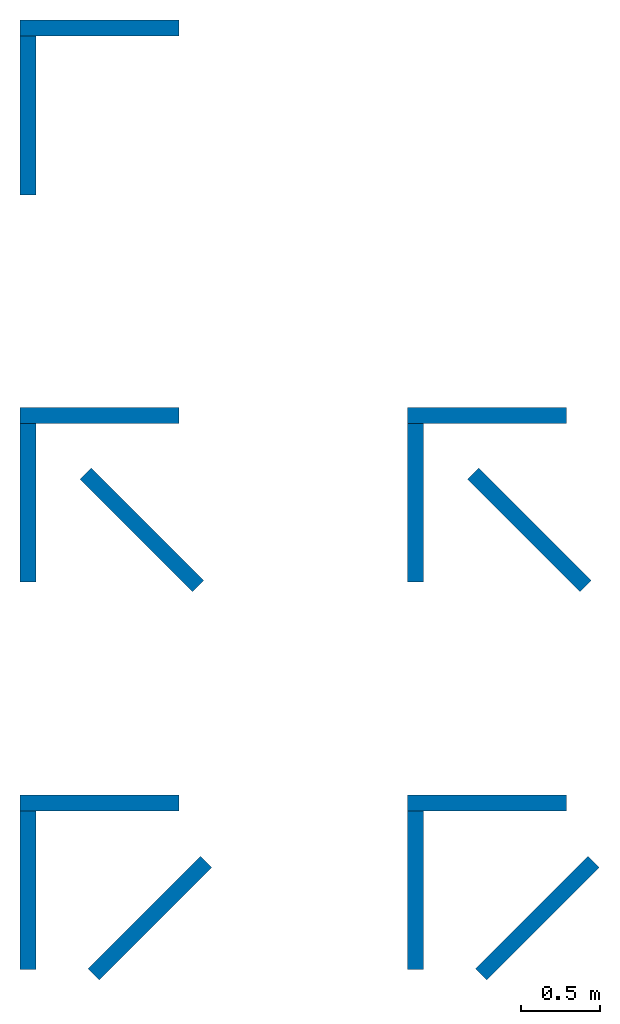
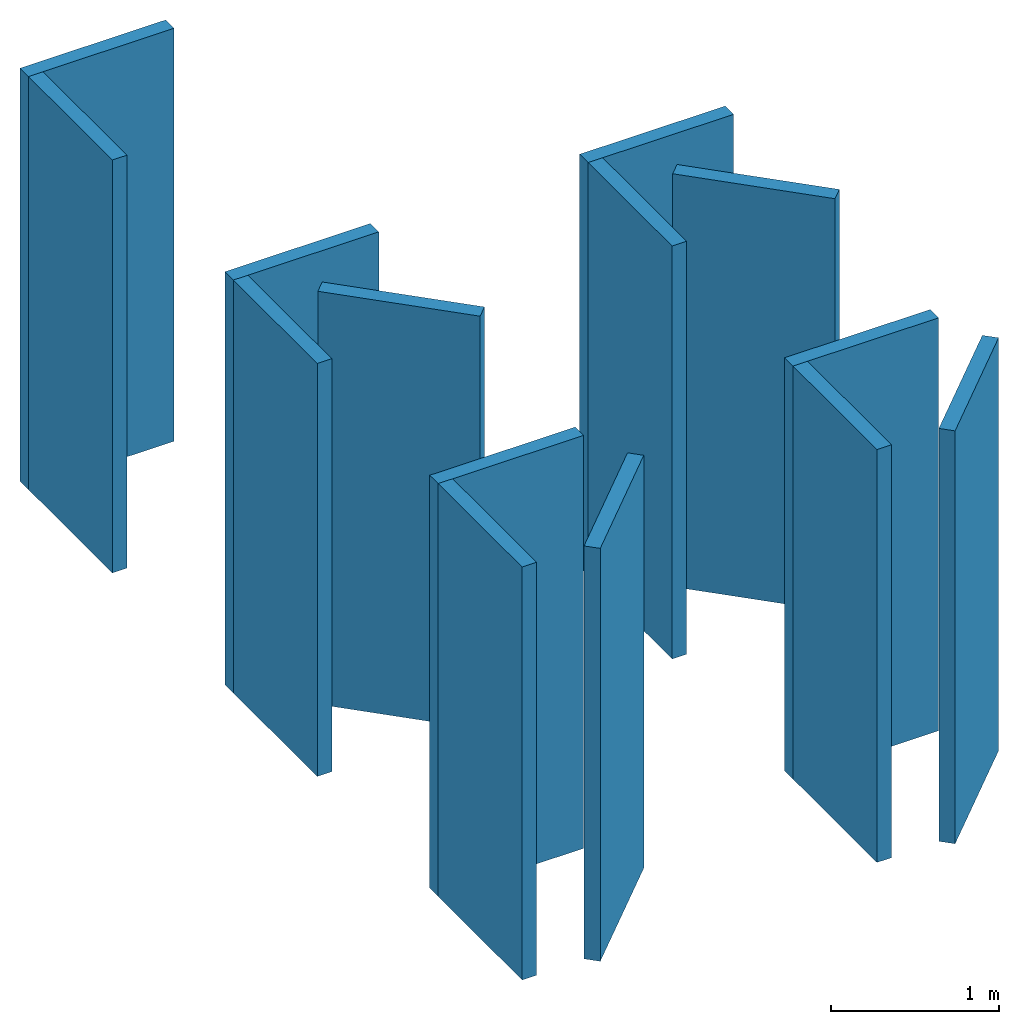
# One storey: 14 walls, 9 elements without a shape of their own.
"""IFC4 building model written with IfcOpenShell, lengths in feet."""

from ifc_helpers import new_model, entity, si_unit, converted_unit, frame, origin_with_axes, origin_2d_with_axis, place, context, subcontext, project, spatial, indexed_curve, outline, extrude, material, layer, layer_set, layer_usage, type_object, element, aggregate, save


model = new_model("IFC4")

# Units and contexts
model_context = context("Model", 3, precision=1e-05, world=origin_with_axes())
plan_context = context("Plan", 2, precision=1e-05, world=origin_2d_with_axis())
body_context = subcontext(model_context, "Body", "Model", "MODEL_VIEW")
ifc_project = project(units=[converted_unit("PLANEANGLEUNIT", "degree", entity("IfcReal", 0.0174532925199433), si_unit("PLANEANGLEUNIT", "RADIAN"), dimensions=[0, 0, 0, 0, 0, 0, 0]), converted_unit("AREAUNIT", "square foot", entity("IfcReal", 0.09290304), si_unit("AREAUNIT", "SQUARE_METRE"), dimensions=[2, 0, 0, 0, 0, 0, 0]), converted_unit("LENGTHUNIT", "foot", entity("IfcReal", 0.3048), si_unit("LENGTHUNIT", "METRE"), dimensions=[1, 0, 0, 0, 0, 0, 0]), converted_unit("VOLUMEUNIT", "cubic foot", entity("IfcReal", 0.0283168467116885), si_unit("VOLUMEUNIT", "CUBIC_METRE"), dimensions=[3, 0, 0, 0, 0, 0, 0])], contexts=[model_context, plan_context])

# Site, building, storey
site_placement = place(None, origin_with_axes())
site = spatial("IfcSite", under=ifc_project, at=site_placement)
building_placement = place(site_placement, origin_with_axes())
building = spatial("IfcBuilding", under=site, at=building_placement, Name="Building")
storey_placement = place(building_placement, origin_with_axes())
storey = spatial("IfcBuildingStorey", under=building, at=storey_placement, Name="Storey")

# Assembly, walls
assembly_1_placement = place(storey_placement, origin_with_axes())
assembly_1 = element("IfcElementAssembly", 1, at=assembly_1_placement, inside=storey, Name="A")
ifc_material = material()
ifc_layer = layer(ifc_material, 0.328083989501312)
ifc_layer_set = layer_set([ifc_layer])
ifc_layer_usage_1 = layer_usage(ifc_layer_set, "AXIS2", "POSITIVE", 0.0)
wall_type = type_object("IfcWallType", Name="WAL100", PredefinedType="NOTDEFINED", material=ifc_layer_set)
wall_1_placement = place(assembly_1_placement, origin_with_axes())
wall_1 = element("IfcWall", 2, at=wall_1_placement, type_object=wall_type, material=ifc_layer_usage_1, Name="Wall", context=body_context, shape_type="SweptSolid", body=[
    extrude(outline(indexed_curve([(0.0, 0.0), (0.0, 0.328083989501312), (3.28083989501312, 0.328083989501312), (3.28083989501312, 0.0), (0.0, 0.0)], self_intersect=False)), origin_with_axes(), (0.0, 0.0, 1.0), 9.84251968503937),
])
ifc_layer_usage_2 = layer_usage(ifc_layer_set, "AXIS2", "POSITIVE", 0.0)
wall_2_placement = place(assembly_1_placement, frame((0.0, 0.0, 0.0), z_axis=(0.0, 0.0, 1.0), x_axis=(-4.37113882867379e-08, -0.999999999999999, 0.0)))
wall_2 = element("IfcWall", 3, at=wall_2_placement, type_object=wall_type, material=ifc_layer_usage_2, Name="Wall", context=body_context, shape_type="SweptSolid", body=[
    extrude(outline(indexed_curve([(0.0, 0.0), (0.0, 0.328083989501312), (3.28083989501312, 0.328083989501312), (3.28083989501312, 0.0), (0.0, 0.0)], self_intersect=False)), origin_with_axes(), (0.0, 0.0, 1.0), 9.84251968503937),
])
aggregate(assembly_1, [wall_1, wall_2])

# Assemblies, walls
assembly_2_placement = place(storey_placement, origin_with_axes())
assembly_2 = element("IfcElementAssembly", 4, at=assembly_2_placement, inside=storey, Name="B")
assembly_3_placement = place(assembly_2_placement, frame((0.0, -8.00000009887175, 0.0), z_axis=(0.0, 0.0, 1.0), x_axis=(1.0, 0.0, 0.0)))
assembly_3 = element("IfcElementAssembly", 5, at=assembly_3_placement, Name="A_Child")
ifc_layer_usage_3 = layer_usage(ifc_layer_set, "AXIS2", "POSITIVE", 0.0)
wall_3_placement = place(assembly_3_placement, origin_with_axes())
wall_3 = element("IfcWall", 6, at=wall_3_placement, type_object=wall_type, material=ifc_layer_usage_3, Name="Wall", context=body_context, shape_type="SweptSolid", body=[
    extrude(outline(indexed_curve([(0.0, 0.0), (0.0, 0.328083989501312), (3.28083989501312, 0.328083989501312), (3.28083989501312, 0.0), (0.0, 0.0)], self_intersect=False)), origin_with_axes(), (0.0, 0.0, 1.0), 9.84251968503937),
])
ifc_layer_usage_4 = layer_usage(ifc_layer_set, "AXIS2", "POSITIVE", 0.0)
wall_4_placement = place(assembly_3_placement, frame((0.0, 0.0, 0.0), z_axis=(0.0, 0.0, 1.0), x_axis=(7.54979012640431e-08, -0.999999999999997, 0.0)))
wall_4 = element("IfcWall", 7, at=wall_4_placement, type_object=wall_type, material=ifc_layer_usage_4, Name="Wall", context=body_context, shape_type="SweptSolid", body=[
    extrude(outline(indexed_curve([(0.0, 0.0), (0.0, 0.328083989501312), (3.28083989501312, 0.328083989501312), (3.28083989501312, 0.0), (0.0, 0.0)], self_intersect=False)), origin_with_axes(), (0.0, 0.0, 1.0), 9.84251968503937),
])
aggregate(assembly_3, [wall_3, wall_4])

assembly_4_placement = place(storey_placement, origin_with_axes())
assembly_4 = element("IfcElementAssembly", 8, at=assembly_4_placement, inside=storey, Name="C")
assembly_5_placement = place(assembly_4_placement, frame((0.0, -16.0000001977435, 0.0), z_axis=(0.0, 0.0, 1.0), x_axis=(1.0, 0.0, 0.0)))
assembly_5 = element("IfcElementAssembly", 9, at=assembly_5_placement, Name="A_Child")
ifc_layer_usage_5 = layer_usage(ifc_layer_set, "AXIS2", "POSITIVE", 0.0)
wall_5_placement = place(assembly_5_placement, origin_with_axes())
wall_5 = element("IfcWall", 10, at=wall_5_placement, type_object=wall_type, material=ifc_layer_usage_5, Name="Wall", context=body_context, shape_type="SweptSolid", body=[
    extrude(outline(indexed_curve([(0.0, 0.0), (0.0, 0.328083989501312), (3.28083989501312, 0.328083989501312), (3.28083989501312, 0.0), (0.0, 0.0)], self_intersect=False)), origin_with_axes(), (0.0, 0.0, 1.0), 9.84251968503937),
])
ifc_layer_usage_6 = layer_usage(ifc_layer_set, "AXIS2", "POSITIVE", 0.0)
wall_6_placement = place(assembly_5_placement, frame((0.0, 0.0, 0.0), z_axis=(0.0, 0.0, 1.0), x_axis=(7.54979012640431e-08, -0.999999999999997, 0.0)))
wall_6 = element("IfcWall", 11, at=wall_6_placement, type_object=wall_type, material=ifc_layer_usage_6, Name="Wall", context=body_context, shape_type="SweptSolid", body=[
    extrude(outline(indexed_curve([(0.0, 0.0), (0.0, 0.328083989501312), (3.28083989501312, 0.328083989501312), (3.28083989501312, 0.0), (0.0, 0.0)], self_intersect=False)), origin_with_axes(), (0.0, 0.0, 1.0), 9.84251968503937),
])
aggregate(assembly_5, [wall_5, wall_6])

# Wall
ifc_layer_usage_7 = layer_usage(ifc_layer_set, "AXIS2", "POSITIVE", 0.0)
wall_7_placement = place(assembly_2_placement, frame((1.23934209190329, -9.15625433283528, 0.0), z_axis=(0.0, 0.0, 1.0), x_axis=(0.707106781186547, -0.707106781186547, 0.0)))
wall_7 = element("IfcWall", 12, at=wall_7_placement, type_object=wall_type, material=ifc_layer_usage_7, Name="Wall", context=body_context, shape_type="SweptSolid", body=[
    extrude(outline(indexed_curve([(0.0, 0.0), (0.0, 0.328083989501312), (3.28083989501312, 0.328083989501312), (3.28083989501312, 0.0), (0.0, 0.0)], self_intersect=False)), origin_with_axes(), (0.0, 0.0, 1.0), 9.84251968503937),
])

aggregate(assembly_2, [assembly_3, wall_7])

ifc_layer_usage_8 = layer_usage(ifc_layer_set, "AXIS2", "POSITIVE", 0.0)
wall_8_placement = place(assembly_4_placement, frame((1.63824568817935, -19.4932985806403, 0.0), z_axis=(0.0, 0.0, 1.0), x_axis=(0.707106781186547, 0.707106781186547, 0.0)))
wall_8 = element("IfcWall", 13, at=wall_8_placement, type_object=wall_type, material=ifc_layer_usage_8, Name="Wall", context=body_context, shape_type="SweptSolid", body=[
    extrude(outline(indexed_curve([(0.0, 0.0), (0.0, 0.328083989501312), (3.28083989501312, 0.328083989501312), (3.28083989501312, 0.0), (0.0, 0.0)], self_intersect=False)), origin_with_axes(), (0.0, 0.0, 1.0), 9.84251968503937),
])

aggregate(assembly_4, [assembly_5, wall_8])

# Assemblies, walls
assembly_6_placement = place(storey_placement, frame((8.00000009887175, 0.0, 0.0), z_axis=(0.0, 0.0, 1.0), x_axis=(1.0, 0.0, 0.0)))
assembly_6 = element("IfcElementAssembly", 14, at=assembly_6_placement, inside=storey, Name="C_Child")
ifc_layer_usage_9 = layer_usage(ifc_layer_set, "AXIS2", "POSITIVE", 0.0)
wall_9_placement = place(assembly_6_placement, frame((1.6382453948494, -19.4932985806403, 0.0), z_axis=(0.0, 0.0, 1.0), x_axis=(0.707106781186547, 0.707106781186547, 0.0)))
wall_9 = element("IfcWall", 15, at=wall_9_placement, type_object=wall_type, material=ifc_layer_usage_9, Name="Wall", context=body_context, shape_type="SweptSolid", body=[
    extrude(outline(indexed_curve([(0.0, 0.0), (0.0, 0.328083989501312), (3.28083989501312, 0.328083989501312), (3.28083989501312, 0.0), (0.0, 0.0)], self_intersect=False)), origin_with_axes(), (0.0, 0.0, 1.0), 9.84251968503937),
])
assembly_7_placement = place(assembly_6_placement, frame((0.0, -16.0000001977435, 0.0), z_axis=(0.0, 0.0, 1.0), x_axis=(1.0, 0.0, 0.0)))
assembly_7 = element("IfcElementAssembly", 16, at=assembly_7_placement, Name="A_Child")
aggregate(assembly_6, [wall_9, assembly_7])
ifc_layer_usage_10 = layer_usage(ifc_layer_set, "AXIS2", "POSITIVE", 0.0)
wall_10_placement = place(assembly_7_placement, frame((0.0, 0.0, 0.0), z_axis=(0.0, 0.0, 1.0), x_axis=(7.54979012640431e-08, -0.999999999999997, 0.0)))
wall_10 = element("IfcWall", 17, at=wall_10_placement, type_object=wall_type, material=ifc_layer_usage_10, Name="Wall", context=body_context, shape_type="SweptSolid", body=[
    extrude(outline(indexed_curve([(0.0, 0.0), (0.0, 0.328083989501312), (3.28083989501312, 0.328083989501312), (3.28083989501312, 0.0), (0.0, 0.0)], self_intersect=False)), origin_with_axes(), (0.0, 0.0, 1.0), 9.84251968503937),
])
ifc_layer_usage_11 = layer_usage(ifc_layer_set, "AXIS2", "POSITIVE", 0.0)
wall_11_placement = place(assembly_7_placement, origin_with_axes())
wall_11 = element("IfcWall", 18, at=wall_11_placement, type_object=wall_type, material=ifc_layer_usage_11, Name="Wall", context=body_context, shape_type="SweptSolid", body=[
    extrude(outline(indexed_curve([(0.0, 0.0), (0.0, 0.328083989501312), (3.28083989501312, 0.328083989501312), (3.28083989501312, 0.0), (0.0, 0.0)], self_intersect=False)), origin_with_axes(), (0.0, 0.0, 1.0), 9.84251968503937),
])
aggregate(assembly_7, [wall_10, wall_11])

assembly_8_placement = place(storey_placement, frame((8.00000009887175, 0.0, 0.0), z_axis=(0.0, 0.0, 1.0), x_axis=(1.0, 0.0, 0.0)))
assembly_8 = element("IfcElementAssembly", 19, at=assembly_8_placement, inside=storey, Name="B_Child")
ifc_layer_usage_12 = layer_usage(ifc_layer_set, "AXIS2", "POSITIVE", 0.0)
wall_12_placement = place(assembly_8_placement, frame((1.23934248300988, -9.15625433283528, 0.0), z_axis=(0.0, 0.0, 1.0), x_axis=(0.707106781186547, -0.707106781186547, 0.0)))
wall_12 = element("IfcWall", 20, at=wall_12_placement, type_object=wall_type, material=ifc_layer_usage_12, Name="Wall", context=body_context, shape_type="SweptSolid", body=[
    extrude(outline(indexed_curve([(0.0, 0.0), (0.0, 0.328083989501312), (3.28083989501312, 0.328083989501312), (3.28083989501312, 0.0), (0.0, 0.0)], self_intersect=False)), origin_with_axes(), (0.0, 0.0, 1.0), 9.84251968503937),
])
assembly_9_placement = place(assembly_8_placement, frame((0.0, -8.00000009887175, 0.0), z_axis=(0.0, 0.0, 1.0), x_axis=(1.0, 0.0, 0.0)))
assembly_9 = element("IfcElementAssembly", 21, at=assembly_9_placement, Name="A_Child")
aggregate(assembly_8, [wall_12, assembly_9])
ifc_layer_usage_13 = layer_usage(ifc_layer_set, "AXIS2", "POSITIVE", 0.0)
wall_13_placement = place(assembly_9_placement, origin_with_axes())
wall_13 = element("IfcWall", 22, at=wall_13_placement, type_object=wall_type, material=ifc_layer_usage_13, Name="Wall", context=body_context, shape_type="SweptSolid", body=[
    extrude(outline(indexed_curve([(0.0, 0.0), (0.0, 0.328083989501312), (3.28083989501312, 0.328083989501312), (3.28083989501312, 0.0), (0.0, 0.0)], self_intersect=False)), origin_with_axes(), (0.0, 0.0, 1.0), 9.84251968503937),
])
ifc_layer_usage_14 = layer_usage(ifc_layer_set, "AXIS2", "POSITIVE", 0.0)
wall_14_placement = place(assembly_9_placement, frame((0.0, 0.0, 0.0), z_axis=(0.0, 0.0, 1.0), x_axis=(7.54979012640431e-08, -0.999999999999997, 0.0)))
wall_14 = element("IfcWall", 23, at=wall_14_placement, type_object=wall_type, material=ifc_layer_usage_14, Name="Wall", context=body_context, shape_type="SweptSolid", body=[
    extrude(outline(indexed_curve([(0.0, 0.0), (0.0, 0.328083989501312), (3.28083989501312, 0.328083989501312), (3.28083989501312, 0.0), (0.0, 0.0)], self_intersect=False)), origin_with_axes(), (0.0, 0.0, 1.0), 9.84251968503937),
])
aggregate(assembly_9, [wall_13, wall_14])

save(model, "model.ifc")
